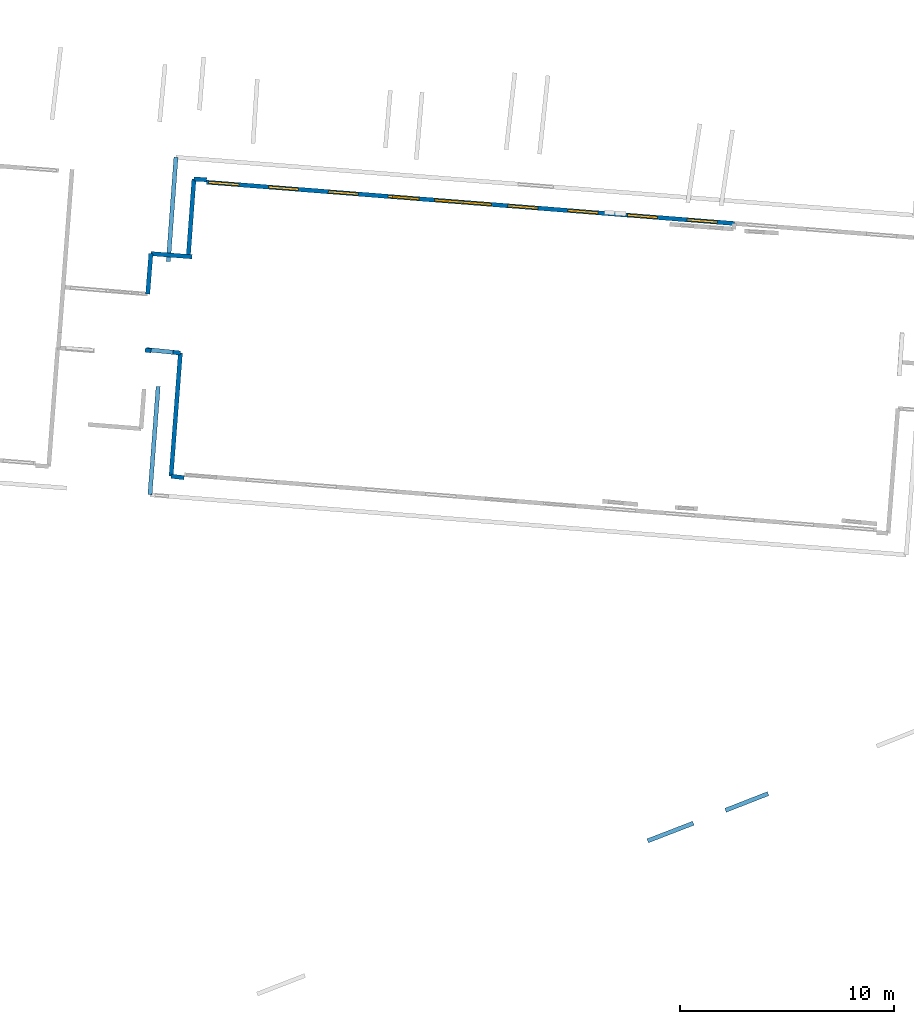
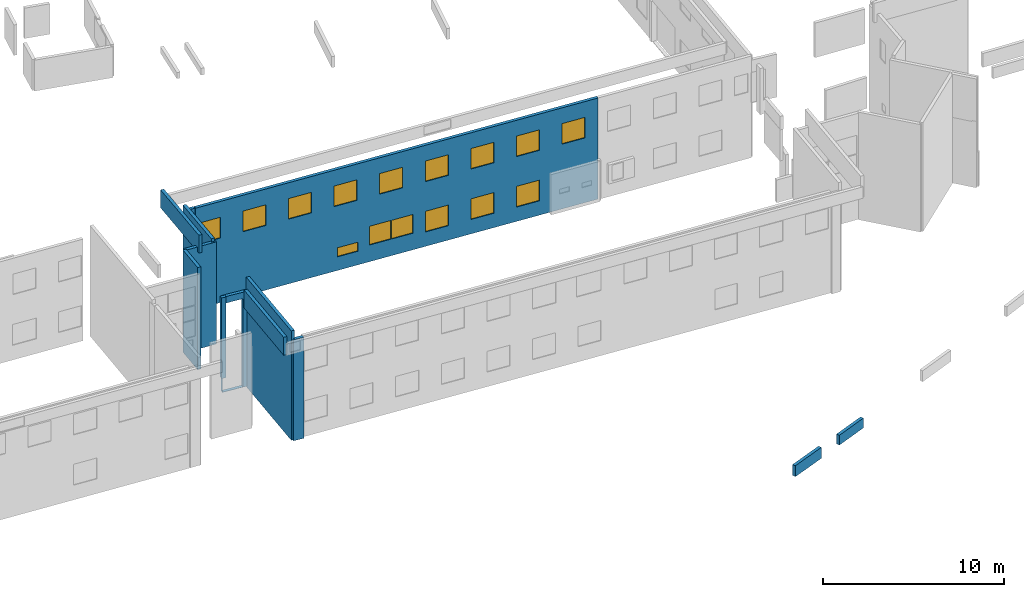
# One storey, part 16 of 27: 15 windows, 13 walls, 16 openings.
"""IFC2X3 building model written with IfcOpenShell, lengths in metres."""

from ifc_helpers import new_model, entity, si_unit, converted_unit, derived_unit, direction, frame, frame_2d, origin, origin_2d_with_axis, place, context, subcontext, project, spatial, polyline, rectangle, outline, extrude, source, transform, mapped, material, layer, layer_set, layer_usage, type_object, type_shapes, element, fill, save


model = new_model("IFC2X3")

# Units and contexts
model_context = context("Model", 3, precision=1e-05, world=origin(), true_north=direction((0.0, 1.0)))
body_context = subcontext(model_context, "Body", "Model", "MODEL_VIEW")
ifc_project = project(units=[si_unit("LENGTHUNIT", "METRE"), si_unit("AREAUNIT", "SQUARE_METRE"), si_unit("VOLUMEUNIT", "CUBIC_METRE"), converted_unit("PLANEANGLEUNIT", "DEGREE", entity("IfcRatioMeasure", 0.0174532925199433), si_unit("PLANEANGLEUNIT", "RADIAN"), dimensions=[0, 0, 0, 0, 0, 0, 0]), si_unit("MASSUNIT", "GRAM", prefix="KILO"), derived_unit("MASSDENSITYUNIT", [(si_unit("MASSUNIT", "GRAM", prefix="KILO"), 1), (si_unit("LENGTHUNIT", "METRE"), -3)]), derived_unit("MOMENTOFINERTIAUNIT", [(si_unit("LENGTHUNIT", "METRE"), 4)]), si_unit("TIMEUNIT", "SECOND"), si_unit("FREQUENCYUNIT", "HERTZ"), si_unit("THERMODYNAMICTEMPERATUREUNIT", "DEGREE_CELSIUS"), derived_unit("THERMALTRANSMITTANCEUNIT", [(si_unit("MASSUNIT", "GRAM", prefix="KILO"), 1), (si_unit("THERMODYNAMICTEMPERATUREUNIT", "KELVIN"), -1), (si_unit("TIMEUNIT", "SECOND"), -3)]), derived_unit("VOLUMETRICFLOWRATEUNIT", [(si_unit("LENGTHUNIT", "METRE"), 3), (si_unit("TIMEUNIT", "SECOND"), -1)]), si_unit("ELECTRICCURRENTUNIT", "AMPERE"), si_unit("ELECTRICVOLTAGEUNIT", "VOLT"), si_unit("POWERUNIT", "WATT"), si_unit("FORCEUNIT", "NEWTON", prefix="KILO"), si_unit("ILLUMINANCEUNIT", "LUX"), si_unit("LUMINOUSFLUXUNIT", "LUMEN"), si_unit("LUMINOUSINTENSITYUNIT", "CANDELA"), derived_unit("USERDEFINED", [(si_unit("MASSUNIT", "GRAM", prefix="KILO"), -1), (si_unit("LENGTHUNIT", "METRE"), -2), (si_unit("TIMEUNIT", "SECOND"), 3), (si_unit("LUMINOUSFLUXUNIT", "LUMEN"), 1)]), derived_unit("LINEARVELOCITYUNIT", [(si_unit("LENGTHUNIT", "METRE"), 1), (si_unit("TIMEUNIT", "SECOND"), -1)]), si_unit("PRESSUREUNIT", "PASCAL"), derived_unit("USERDEFINED", [(si_unit("LENGTHUNIT", "METRE"), -2), (si_unit("MASSUNIT", "GRAM", prefix="KILO"), 1), (si_unit("TIMEUNIT", "SECOND"), -2)]), derived_unit("LINEARFORCEUNIT", [(si_unit("MASSUNIT", "GRAM", prefix="KILO"), 1), (si_unit("LENGTHUNIT", "METRE"), 1), (si_unit("TIMEUNIT", "SECOND"), -2), (si_unit("LENGTHUNIT", "METRE"), -1)]), derived_unit("PLANARFORCEUNIT", [(si_unit("MASSUNIT", "GRAM", prefix="KILO"), 1), (si_unit("LENGTHUNIT", "METRE"), 1), (si_unit("TIMEUNIT", "SECOND"), -2), (si_unit("LENGTHUNIT", "METRE"), -2)])], contexts=[model_context])

# Site, building, storey
placement_1 = place(None, origin())
site = spatial("IfcSite", under=ifc_project, at=placement_1, CompositionType="ELEMENT")
building = spatial("IfcBuilding", under=site, at=placement_1, CompositionType="ELEMENT")
storey_placement = place(placement_1, frame((0.0, 0.0, -61.043098449707)))
storey = spatial("IfcBuildingStorey", under=building, at=storey_placement, Name="level_-61.043098", CompositionType="ELEMENT", Elevation=-61.043098449707)

# Walls
ifc_material_1 = material(Name="Default wall")
ifc_layer = layer(ifc_material_1, 0.2)
ifc_layer_set = layer_set([ifc_layer], Name="wall_thickness_0.2000")
ifc_layer_usage = layer_usage(ifc_layer_set, "AXIS2", "POSITIVE", -0.1)
wall_type = type_object("IfcWallType", Name="wall_thickness_0.2000", PredefinedType="STANDARD", material=ifc_layer_set)
wall_1_placement = place(storey_placement, frame((-30.3327727331581, -6.27983924599841, 0.0), z_axis=(0.0, 0.0, 1.0), x_axis=(-0.997044721434265, 0.0768233262757455, 0.0)))
element("IfcWallStandardCase", 1, at=wall_1_placement, inside=storey, type_object=wall_type, material=ifc_layer_usage, Name="Wall:340", ObjectType="Wall", context=body_context, shape_type="SweptSolid", body=[
    extrude(outline(polyline([(1.92745099163823, -0.1), (1.92745099163823, 0.1), (0.0, 0.1), (0.0, -0.1), (1.92745099163823, -0.1)])), origin(), (0.0, 0.0, 1.0), 6.90997695922852),
])
placement_2 = place(placement_1, frame((0.0, 0.0, -54.4207000732422)))
wall_2_placement = place(placement_2, frame((-31.4420314985094, -6.4970824423549, 0.0), z_axis=(0.0, 0.0, 1.0), x_axis=(0.0732878255302598, 0.997310831500915, 0.0)))
element("IfcWallStandardCase", 2, at=wall_2_placement, inside=storey, type_object=wall_type, material=ifc_layer_usage, Name="Wall:399", ObjectType="Wall", context=body_context, shape_type="SweptSolid", body=[
    extrude(outline(polyline([(4.87123551173419, -0.1), (4.87123551173419, 0.1), (0.0, 0.1), (0.0, -0.1), (4.87123551173419, -0.1)])), origin(), (0.0, 0.0, 1.0), 1.21003723144531),
])
wall_3_placement = place(storey_placement, frame((-30.2444584945252, -2.65084213138611, 0.0), z_axis=(0.0, 0.0, 1.0), x_axis=(-0.0734079039568483, -0.997302000216916, 0.0)))
element("IfcWallStandardCase", 3, at=wall_3_placement, inside=storey, type_object=wall_type, material=ifc_layer_usage, Name="Wall:659", ObjectType="Wall", context=body_context, shape_type="SweptSolid", body=[
    extrude(outline(polyline([(3.62507921094114, -0.1), (3.62507921094114, 0.1), (0.0, 0.1), (0.0, -0.1), (3.62507921094114, -0.1)])), origin(), (0.0, 0.0, 1.0), 7.12580871582031),
])
wall_4_placement = place(storey_placement, frame((-29.6513659251142, -2.68648694325276, 0.0), z_axis=(0.0, 0.0, 1.0), x_axis=(-0.998198842081799, 0.059992263389174, 0.0)))
element("IfcWallStandardCase", 4, at=wall_4_placement, inside=storey, type_object=wall_type, material=ifc_layer_usage, Name="Wall:709", ObjectType="Wall", context=body_context, shape_type="SweptSolid", body=[
    extrude(outline(polyline([(0.594164055363341, -0.1), (0.594164055363341, 0.1), (0.0, 0.1), (0.0, -0.1), (0.594164055363341, -0.1)])), origin(), (0.0, 0.0, 1.0), 6.76219177246094),
])
placement_3 = place(placement_1, frame((0.0, 0.0, -59.9867630004883)))
wall_5_placement = place(placement_3, frame((-32.2471248701736, -10.6648249749143, 0.0), z_axis=(0.0, 0.0, 1.0), x_axis=(-0.990595692429401, 0.136821687390254, 0.0)))
element("IfcWallStandardCase", 5, at=wall_5_placement, inside=storey, type_object=wall_type, material=ifc_layer_usage, Name="Wall:744", ObjectType="Wall", context=body_context, shape_type="SweptSolid", body=[
    extrude(outline(polyline([(0.279999842825242, -0.1), (0.279999842825242, 0.1), (0.0, 0.1), (0.0, -0.1), (0.279999842825242, -0.1)])), origin(), (0.0, 0.0, 1.0), 5.45549392700195),
])
placement_4 = place(placement_1, frame((0.0, 0.0, -60.9578857421875)))
wall_6_placement = place(placement_4, frame((-5.4558861288516, -32.0961691788936, 0.0), z_axis=(0.0, 0.0, 1.0), x_axis=(0.931288838013348, 0.364281622088938, 0.0)))
element("IfcWallStandardCase", 6, at=wall_6_placement, inside=storey, type_object=wall_type, material=ifc_layer_usage, Name="Wall:798", ObjectType="Wall", context=body_context, shape_type="SweptSolid", body=[
    extrude(outline(polyline([(2.13644295936585, -0.1), (2.13644295936585, 0.1), (0.0, 0.1), (0.0, -0.1), (2.13644295936585, -0.1)])), origin(), (0.0, 0.0, 1.0), 0.661750793457031),
])

# Wall, opening
placement_5 = place(placement_1, frame((0.0, 0.0, -60.9578857421875)))
wall_7_placement = place(placement_5, frame((-30.8788948436771, -10.7677606037389, 0.0), z_axis=(0.0, 0.0, 1.0), x_axis=(-0.994879274320708, 0.101070418655023, 0.0)))
wall_7 = element("IfcWallStandardCase", 7, at=wall_7_placement, inside=storey, type_object=wall_type, material=ifc_layer_usage, Name="Wall:1042", ObjectType="Wall", context=body_context, shape_type="SweptSolid", body=[
    extrude(outline(polyline([(1.58687465278728, -0.1), (1.58687465278728, 0.1), (0.0, 0.1), (0.0, -0.1), (1.58687465278728, -0.1)])), origin(), (0.0, 0.0, 1.0), 6.42661666870117),
])
opening_1_placement = place(wall_7_placement, frame((0.341874747974041, -0.1, 0.01629638671875)))
element("IfcOpeningElement", 8, at=opening_1_placement, cuts=wall_7, Name="Opening : 1240 x 5970 : 132", ObjectType="Opening", context=body_context, shape_type="SweptSolid", body=[
    extrude(rectangle(XDim=1.24, YDim=5.97, at=frame_2d((2.985, 0.62), x_axis=(0.0, 1.0))), frame((0.0, 0.0, 0.0), z_axis=(0.0, 1.0, 0.0), x_axis=(0.0, 0.0, 1.0)), (0.0, 0.0, 1.0), 0.2),
])

# Walls
wall_8_placement = place(storey_placement, frame((-32.2545255454813, -6.1317669821231, 0.0), z_axis=(0.0, 0.0, 1.0), x_axis=(-0.0784278699019514, -0.996919790766861, 0.0)))
element("IfcWallStandardCase", 9, at=wall_8_placement, inside=storey, type_object=wall_type, material=ifc_layer_usage, Name="Wall:1142", ObjectType="Wall", context=body_context, shape_type="SweptSolid", body=[
    extrude(outline(polyline([(1.89412183581786, -0.1), (1.89412183581786, 0.1), (0.0, 0.1), (0.0, -0.1), (1.89412183581786, -0.1)])), origin(), (0.0, 0.0, 1.0), 6.90997695922852),
])
wall_9_placement = place(storey_placement, frame((-30.7055690613934, -16.5812876091404, 0.0), z_axis=(0.0, 0.0, 1.0), x_axis=(-0.994031352901051, 0.109094772788184, 0.0)))
element("IfcWallStandardCase", 10, at=wall_9_placement, inside=storey, type_object=wall_type, material=ifc_layer_usage, Name="Wall:1145", ObjectType="Wall", context=body_context, shape_type="SweptSolid", body=[
    extrude(outline(polyline([(0.612373915866722, -0.1), (0.612373915866722, 0.1), (0.0, 0.1), (0.0, -0.1), (0.612373915866722, -0.1)])), origin(), (0.0, 0.0, 1.0), 6.83392333984375),
])
placement_6 = place(placement_1, frame((0.0, 0.0, -54.4207000732422)))
wall_10_placement = place(placement_6, frame((-32.2988607983312, -17.3784642437076, 0.0), z_axis=(0.0, 0.0, 1.0), x_axis=(0.0755069059998019, 0.997145278856766, 0.0)))
element("IfcWallStandardCase", 11, at=wall_10_placement, inside=storey, type_object=wall_type, material=ifc_layer_usage, Name="Wall:1306", ObjectType="Wall", context=body_context, shape_type="SweptSolid", body=[
    extrude(outline(polyline([(5.06280226917499, -0.1), (5.06280226917499, 0.1), (0.0, 0.1), (0.0, -0.1), (5.06280226917499, -0.1)])), origin(), (0.0, 0.0, 1.0), 1.21003723144531),
])

# Wall, openings, windows
wall_11_placement = place(storey_placement, frame((-29.6602502687136, -2.79993296057398, 0.0), z_axis=(0.0, 0.0, 1.0), x_axis=(0.996952097446105, -0.078016122678657, 0.0)))
wall_11 = element("IfcWallStandardCase", 12, at=wall_11_placement, inside=storey, type_object=wall_type, material=ifc_layer_usage, Name="Wall:1582", ObjectType="Wall", context=body_context, shape_type="SweptSolid", body=[
    extrude(outline(polyline([(24.6974745543015, -0.1), (24.6974745543015, 0.1), (0.0, 0.1), (0.0, -0.1), (24.6974745543015, -0.1)])), origin(), (0.0, 0.0, 1.0), 6.83392333984375),
])
opening_2_placement = place(wall_11_placement, frame((10.6622287166281, -0.1, 1.12677001953125)))
opening_2 = element("IfcOpeningElement", 13, at=opening_2_placement, cuts=wall_11, Name="Opening : 1330 x 1265 : 244", ObjectType="Opening", context=body_context, shape_type="SweptSolid", body=[
    extrude(rectangle(XDim=1.33, YDim=1.265, at=frame_2d((0.6325, 0.665), x_axis=(0.0, 1.0))), frame((0.0, 0.0, 0.0), z_axis=(0.0, 1.0, 0.0), x_axis=(0.0, 0.0, 1.0)), (0.0, 0.0, 1.0), 0.2),
])
opening_3_placement = place(wall_11_placement, frame((12.01713744686, -0.1, 1.12176895141602)))
opening_3 = element("IfcOpeningElement", 14, at=opening_3_placement, cuts=wall_11, Name="Opening : 1320 x 1265 : 245", ObjectType="Opening", context=body_context, shape_type="SweptSolid", body=[
    extrude(rectangle(XDim=1.32, YDim=1.265, at=frame_2d((0.6325, 0.66), x_axis=(0.0, 1.0))), frame((0.0, 0.0, 0.0), z_axis=(0.0, 1.0, 0.0), x_axis=(0.0, 0.0, 1.0)), (0.0, 0.0, 1.0), 0.2),
])
opening_4_placement = place(wall_11_placement, frame((8.49587485002833, -0.1, 4.37840270996094)))
opening_4 = element("IfcOpeningElement", 15, at=opening_4_placement, cuts=wall_11, Name="Opening : 1405 x 1390 : 246", ObjectType="Opening", context=body_context, shape_type="SweptSolid", body=[
    extrude(rectangle(XDim=1.405, YDim=1.39, at=frame_2d((0.695, 0.7025), x_axis=(0.0, 1.0))), frame((0.0, 0.0, 0.0), z_axis=(0.0, 1.0, 0.0), x_axis=(0.0, 0.0, 1.0)), (0.0, 0.0, 1.0), 0.2),
])
opening_5_placement = place(wall_11_placement, frame((11.2908736870222, -0.1, 4.37840270996094)))
opening_5 = element("IfcOpeningElement", 16, at=opening_5_placement, cuts=wall_11, Name="Opening : 1410 x 1390 : 247", ObjectType="Opening", context=body_context, shape_type="SweptSolid", body=[
    extrude(rectangle(XDim=1.41, YDim=1.39, at=frame_2d((0.695, 0.705), x_axis=(0.0, 1.0))), frame((0.0, 0.0, 0.0), z_axis=(0.0, 1.0, 0.0), x_axis=(0.0, 0.0, 1.0)), (0.0, 0.0, 1.0), 0.2),
])
opening_6_placement = place(wall_11_placement, frame((14.0908745368561, -0.1, 4.37840270996094)))
opening_6 = element("IfcOpeningElement", 17, at=opening_6_placement, cuts=wall_11, Name="Opening : 1410 x 1390 : 248", ObjectType="Opening", context=body_context, shape_type="SweptSolid", body=[
    extrude(rectangle(XDim=1.41, YDim=1.39, at=frame_2d((0.695, 0.705), x_axis=(0.0, 1.0))), frame((0.0, 0.0, 0.0), z_axis=(0.0, 1.0, 0.0), x_axis=(0.0, 0.0, 1.0)), (0.0, 0.0, 1.0), 0.2),
])
opening_7_placement = place(wall_11_placement, frame((16.900874621331, -0.1, 4.38339996337891)))
opening_7 = element("IfcOpeningElement", 18, at=opening_7_placement, cuts=wall_11, Name="Opening : 1410 x 1385 : 249", ObjectType="Opening", context=body_context, shape_type="SweptSolid", body=[
    extrude(rectangle(XDim=1.41, YDim=1.385, at=frame_2d((0.6925, 0.705), x_axis=(0.0, 1.0))), frame((0.0, 0.0, 0.0), z_axis=(0.0, 1.0, 0.0), x_axis=(0.0, 0.0, 1.0)), (0.0, 0.0, 1.0), 0.2),
])
opening_8_placement = place(wall_11_placement, frame((19.695874390492, -0.1, 4.38339996337891)))
opening_8 = element("IfcOpeningElement", 19, at=opening_8_placement, cuts=wall_11, Name="Opening : 1410 x 1385 : 250", ObjectType="Opening", context=body_context, shape_type="SweptSolid", body=[
    extrude(rectangle(XDim=1.41, YDim=1.385, at=frame_2d((0.6925, 0.705), x_axis=(0.0, 1.0))), frame((0.0, 0.0, 0.0), z_axis=(0.0, 1.0, 0.0), x_axis=(0.0, 0.0, 1.0)), (0.0, 0.0, 1.0), 0.2),
])
opening_9_placement = place(wall_11_placement, frame((22.485873153382, -0.1, 4.37840270996094)))
opening_9 = element("IfcOpeningElement", 20, at=opening_9_placement, cuts=wall_11, Name="Opening : 1410 x 1390 : 251", ObjectType="Opening", context=body_context, shape_type="SweptSolid", body=[
    extrude(rectangle(XDim=1.41, YDim=1.39, at=frame_2d((0.695, 0.705), x_axis=(0.0, 1.0))), frame((0.0, 0.0, 0.0), z_axis=(0.0, 1.0, 0.0), x_axis=(0.0, 0.0, 1.0)), (0.0, 0.0, 1.0), 0.2),
])
opening_10_placement = place(wall_11_placement, frame((0.100005771037718, -0.1, 4.35840225219727)))
opening_10 = element("IfcOpeningElement", 21, at=opening_10_placement, cuts=wall_11, Name="Opening : 1410 x 1405 : 252", ObjectType="Opening", context=body_context, shape_type="SweptSolid", body=[
    extrude(rectangle(XDim=1.41, YDim=1.405, at=frame_2d((0.7025, 0.705), x_axis=(0.0, 1.0))), frame((0.0, 0.0, 0.0), z_axis=(0.0, 1.0, 0.0), x_axis=(0.0, 0.0, 1.0)), (0.0, 0.0, 1.0), 0.2),
])
opening_11_placement = place(wall_11_placement, frame((2.89587507049625, -0.1, 4.36840057373047)))
opening_11 = element("IfcOpeningElement", 22, at=opening_11_placement, cuts=wall_11, Name="Opening : 1405 x 1395 : 253", ObjectType="Opening", context=body_context, shape_type="SweptSolid", body=[
    extrude(rectangle(XDim=1.405, YDim=1.395, at=frame_2d((0.6975, 0.7025), x_axis=(0.0, 1.0))), frame((0.0, 0.0, 0.0), z_axis=(0.0, 1.0, 0.0), x_axis=(0.0, 0.0, 1.0)), (0.0, 0.0, 1.0), 0.2),
])
opening_12_placement = place(wall_11_placement, frame((5.69587496956254, -0.1, 4.3734016418457)))
opening_12 = element("IfcOpeningElement", 23, at=opening_12_placement, cuts=wall_11, Name="Opening : 1410 x 1390 : 254", ObjectType="Opening", context=body_context, shape_type="SweptSolid", body=[
    extrude(rectangle(XDim=1.41, YDim=1.39, at=frame_2d((0.695, 0.705), x_axis=(0.0, 1.0))), frame((0.0, 0.0, 0.0), z_axis=(0.0, 1.0, 0.0), x_axis=(0.0, 0.0, 1.0)), (0.0, 0.0, 1.0), 0.2),
])
opening_13_placement = place(wall_11_placement, frame((14.0958746295604, -0.1, 0.973400115966797)))
opening_13 = element("IfcOpeningElement", 24, at=opening_13_placement, cuts=wall_11, Name="Opening : 1410 x 1395 : 255", ObjectType="Opening", context=body_context, shape_type="SweptSolid", body=[
    extrude(rectangle(XDim=1.41, YDim=1.395, at=frame_2d((0.6975, 0.705), x_axis=(0.0, 1.0))), frame((0.0, 0.0, 0.0), z_axis=(0.0, 1.0, 0.0), x_axis=(0.0, 0.0, 1.0)), (0.0, 0.0, 1.0), 0.2),
])
opening_14_placement = place(wall_11_placement, frame((16.8958735406581, -0.1, 0.973400115966797)))
opening_14 = element("IfcOpeningElement", 25, at=opening_14_placement, cuts=wall_11, Name="Opening : 1415 x 1395 : 256", ObjectType="Opening", context=body_context, shape_type="SweptSolid", body=[
    extrude(rectangle(XDim=1.415, YDim=1.395, at=frame_2d((0.6975, 0.7075), x_axis=(0.0, 1.0))), frame((0.0, 0.0, 0.0), z_axis=(0.0, 1.0, 0.0), x_axis=(0.0, 0.0, 1.0)), (0.0, 0.0, 1.0), 0.2),
])
opening_15_placement = place(wall_11_placement, frame((19.6908733470201, -0.1, 0.968399047851562)))
opening_15 = element("IfcOpeningElement", 26, at=opening_15_placement, cuts=wall_11, Name="Opening : 1415 x 1400 : 257", ObjectType="Opening", context=body_context, shape_type="SweptSolid", body=[
    extrude(rectangle(XDim=1.415, YDim=1.4, at=frame_2d((0.7, 0.7075), x_axis=(0.0, 1.0))), frame((0.0, 0.0, 0.0), z_axis=(0.0, 1.0, 0.0), x_axis=(0.0, 0.0, 1.0)), (0.0, 0.0, 1.0), 0.2),
])
opening_16_placement = place(wall_11_placement, frame((8.70461998163483, -0.1, 0.921886444091797)))
opening_16 = element("IfcOpeningElement", 27, at=opening_16_placement, cuts=wall_11, Name="Opening : 1240 x 610 : 258", ObjectType="Opening", context=body_context, shape_type="SweptSolid", body=[
    extrude(rectangle(XDim=1.24, YDim=0.61, at=frame_2d((0.305, 0.62), x_axis=(0.0, 1.0))), frame((0.0, 0.0, 0.0), z_axis=(0.0, 1.0, 0.0), x_axis=(0.0, 0.0, 1.0)), (0.0, 0.0, 1.0), 0.2),
])
ifc_material_2 = material(Name="Window Default")
window_style_1 = type_object("IfcWindowStyle", Name="Window : 1410 x 1395mm", ConstructionType="NOTDEFINED", OperationType="NOTDEFINED", ParameterTakesPrecedence=False, Sizeable=False, material=ifc_material_2)
shared_shape_1 = source(origin(), body_context, "Body", "SweptSolid", [
    extrude(rectangle(XDim=0.1, YDim=1.41, at=origin_2d_with_axis()), frame((0.705, 0.1, 0.0), z_axis=(0.0, 0.0, 1.0), x_axis=(0.0, 1.0, 0.0)), (0.0, 0.0, 1.0), 1.395),
])
type_shapes(window_style_1, [shared_shape_1])
window_1_placement = place(opening_13_placement, origin())
window_1 = element("IfcWindow", 28, at=window_1_placement, inside=storey, type_object=window_style_1, Name="Window : 1410 x 1395mm : 238", ObjectType="Window : 1410 x 1395mm", OverallHeight=1.395, OverallWidth=1.41, context=body_context, shape_type="MappedRepresentation", body=[
    mapped(shared_shape_1, transform((0.0, 0.0, 0.0), scale=1.0)),
])
fill(opening_13, window_1)
window_style_2 = type_object("IfcWindowStyle", Name="Window : 1410 x 1390mm", ConstructionType="NOTDEFINED", OperationType="NOTDEFINED", ParameterTakesPrecedence=False, Sizeable=False, material=ifc_material_2)
shared_shape_2 = source(origin(), body_context, "Body", "SweptSolid", [
    extrude(rectangle(XDim=0.1, YDim=1.41, at=origin_2d_with_axis()), frame((0.705, 0.1, 0.0), z_axis=(0.0, 0.0, 1.0), x_axis=(0.0, 1.0, 0.0)), (0.0, 0.0, 1.0), 1.39),
])
type_shapes(window_style_2, [shared_shape_2])
window_2_placement = place(opening_5_placement, origin())
window_2 = element("IfcWindow", 29, at=window_2_placement, inside=storey, type_object=window_style_2, Name="Window : 1410 x 1390mm : 230", ObjectType="Window : 1410 x 1390mm", OverallHeight=1.39, OverallWidth=1.41, context=body_context, shape_type="MappedRepresentation", body=[
    mapped(shared_shape_2, transform((0.0, 0.0, 0.0), scale=1.0)),
])
fill(opening_5, window_2)
window_3_placement = place(opening_6_placement, origin())
window_3 = element("IfcWindow", 30, at=window_3_placement, inside=storey, type_object=window_style_2, Name="Window : 1410 x 1390mm : 231", ObjectType="Window : 1410 x 1390mm", OverallHeight=1.39, OverallWidth=1.41, context=body_context, shape_type="MappedRepresentation", body=[
    mapped(shared_shape_2, transform((0.0, 0.0, 0.0), scale=1.0)),
])
fill(opening_6, window_3)
window_4_placement = place(opening_9_placement, origin())
window_4 = element("IfcWindow", 31, at=window_4_placement, inside=storey, type_object=window_style_2, Name="Window : 1410 x 1390mm : 234", ObjectType="Window : 1410 x 1390mm", OverallHeight=1.39, OverallWidth=1.41, context=body_context, shape_type="MappedRepresentation", body=[
    mapped(shared_shape_2, transform((0.0, 0.0, 0.0), scale=1.0)),
])
fill(opening_9, window_4)
window_5_placement = place(opening_12_placement, origin())
window_5 = element("IfcWindow", 32, at=window_5_placement, inside=storey, type_object=window_style_2, Name="Window : 1410 x 1390mm : 237", ObjectType="Window : 1410 x 1390mm", OverallHeight=1.39, OverallWidth=1.41, context=body_context, shape_type="MappedRepresentation", body=[
    mapped(shared_shape_2, transform((0.0, 0.0, 0.0), scale=1.0)),
])
fill(opening_12, window_5)
window_style_3 = type_object("IfcWindowStyle", Name="Window : 1415 x 1400mm", ConstructionType="NOTDEFINED", OperationType="NOTDEFINED", ParameterTakesPrecedence=False, Sizeable=False, material=ifc_material_2)
shared_shape_3 = source(origin(), body_context, "Body", "SweptSolid", [
    extrude(rectangle(XDim=0.1, YDim=1.415, at=origin_2d_with_axis()), frame((0.7075, 0.1, 0.0), z_axis=(0.0, 0.0, 1.0), x_axis=(0.0, 1.0, 0.0)), (0.0, 0.0, 1.0), 1.4),
])
type_shapes(window_style_3, [shared_shape_3])
window_6_placement = place(opening_15_placement, origin())
window_6 = element("IfcWindow", 33, at=window_6_placement, inside=storey, type_object=window_style_3, Name="Window : 1415 x 1400mm : 240", ObjectType="Window : 1415 x 1400mm", OverallHeight=1.4, OverallWidth=1.415, context=body_context, shape_type="MappedRepresentation", body=[
    mapped(shared_shape_3, transform((0.0, 0.0, 0.0), scale=1.0)),
])
fill(opening_15, window_6)
window_style_4 = type_object("IfcWindowStyle", Name="Window : 1405 x 1395mm", ConstructionType="NOTDEFINED", OperationType="NOTDEFINED", ParameterTakesPrecedence=False, Sizeable=False, material=ifc_material_2)
shared_shape_4 = source(origin(), body_context, "Body", "SweptSolid", [
    extrude(rectangle(XDim=0.1, YDim=1.405, at=origin_2d_with_axis()), frame((0.7025, 0.1, 0.0), z_axis=(0.0, 0.0, 1.0), x_axis=(0.0, 1.0, 0.0)), (0.0, 0.0, 1.0), 1.395),
])
type_shapes(window_style_4, [shared_shape_4])
window_7_placement = place(opening_11_placement, origin())
window_7 = element("IfcWindow", 34, at=window_7_placement, inside=storey, type_object=window_style_4, Name="Window : 1405 x 1395mm : 236", ObjectType="Window : 1405 x 1395mm", OverallHeight=1.395, OverallWidth=1.405, context=body_context, shape_type="MappedRepresentation", body=[
    mapped(shared_shape_4, transform((0.0, 0.0, 0.0), scale=1.0)),
])
fill(opening_11, window_7)
window_style_5 = type_object("IfcWindowStyle", Name="Window : 1415 x 1395mm", ConstructionType="NOTDEFINED", OperationType="NOTDEFINED", ParameterTakesPrecedence=False, Sizeable=False, material=ifc_material_2)
shared_shape_5 = source(origin(), body_context, "Body", "SweptSolid", [
    extrude(rectangle(XDim=0.1, YDim=1.415, at=origin_2d_with_axis()), frame((0.7075, 0.1, 0.0), z_axis=(0.0, 0.0, 1.0), x_axis=(0.0, 1.0, 0.0)), (0.0, 0.0, 1.0), 1.395),
])
type_shapes(window_style_5, [shared_shape_5])
window_8_placement = place(opening_14_placement, origin())
window_8 = element("IfcWindow", 35, at=window_8_placement, inside=storey, type_object=window_style_5, Name="Window : 1415 x 1395mm : 239", ObjectType="Window : 1415 x 1395mm", OverallHeight=1.395, OverallWidth=1.415, context=body_context, shape_type="MappedRepresentation", body=[
    mapped(shared_shape_5, transform((0.0, 0.0, 0.0), scale=1.0)),
])
fill(opening_14, window_8)
window_style_6 = type_object("IfcWindowStyle", Name="Window : 1410 x 1385mm", ConstructionType="NOTDEFINED", OperationType="NOTDEFINED", ParameterTakesPrecedence=False, Sizeable=False, material=ifc_material_2)
shared_shape_6 = source(origin(), body_context, "Body", "SweptSolid", [
    extrude(rectangle(XDim=0.1, YDim=1.41, at=origin_2d_with_axis()), frame((0.705, 0.1, 0.0), z_axis=(0.0, 0.0, 1.0), x_axis=(0.0, 1.0, 0.0)), (0.0, 0.0, 1.0), 1.385),
])
type_shapes(window_style_6, [shared_shape_6])
window_9_placement = place(opening_7_placement, origin())
window_9 = element("IfcWindow", 36, at=window_9_placement, inside=storey, type_object=window_style_6, Name="Window : 1410 x 1385mm : 232", ObjectType="Window : 1410 x 1385mm", OverallHeight=1.385, OverallWidth=1.41, context=body_context, shape_type="MappedRepresentation", body=[
    mapped(shared_shape_6, transform((0.0, 0.0, 0.0), scale=1.0)),
])
fill(opening_7, window_9)
window_10_placement = place(opening_8_placement, origin())
window_10 = element("IfcWindow", 37, at=window_10_placement, inside=storey, type_object=window_style_6, Name="Window : 1410 x 1385mm : 233", ObjectType="Window : 1410 x 1385mm", OverallHeight=1.385, OverallWidth=1.41, context=body_context, shape_type="MappedRepresentation", body=[
    mapped(shared_shape_6, transform((0.0, 0.0, 0.0), scale=1.0)),
])
fill(opening_8, window_10)
window_style_7 = type_object("IfcWindowStyle", Name="Window : 1405 x 1390mm", ConstructionType="NOTDEFINED", OperationType="NOTDEFINED", ParameterTakesPrecedence=False, Sizeable=False, material=ifc_material_2)
shared_shape_7 = source(origin(), body_context, "Body", "SweptSolid", [
    extrude(rectangle(XDim=0.1, YDim=1.405, at=origin_2d_with_axis()), frame((0.7025, 0.1, 0.0), z_axis=(0.0, 0.0, 1.0), x_axis=(0.0, 1.0, 0.0)), (0.0, 0.0, 1.0), 1.39),
])
type_shapes(window_style_7, [shared_shape_7])
window_11_placement = place(opening_4_placement, origin())
window_11 = element("IfcWindow", 38, at=window_11_placement, inside=storey, type_object=window_style_7, Name="Window : 1405 x 1390mm : 229", ObjectType="Window : 1405 x 1390mm", OverallHeight=1.39, OverallWidth=1.405, context=body_context, shape_type="MappedRepresentation", body=[
    mapped(shared_shape_7, transform((0.0, 0.0, 0.0), scale=1.0)),
])
fill(opening_4, window_11)
window_style_8 = type_object("IfcWindowStyle", Name="Window : 1330 x 1265mm", ConstructionType="NOTDEFINED", OperationType="NOTDEFINED", ParameterTakesPrecedence=False, Sizeable=False, material=ifc_material_2)
shared_shape_8 = source(origin(), body_context, "Body", "SweptSolid", [
    extrude(rectangle(XDim=0.1, YDim=1.33, at=origin_2d_with_axis()), frame((0.665, 0.1, 0.0), z_axis=(0.0, 0.0, 1.0), x_axis=(0.0, 1.0, 0.0)), (0.0, 0.0, 1.0), 1.265),
])
type_shapes(window_style_8, [shared_shape_8])
window_12_placement = place(opening_2_placement, origin())
window_12 = element("IfcWindow", 39, at=window_12_placement, inside=storey, type_object=window_style_8, Name="Window : 1330 x 1265mm : 227", ObjectType="Window : 1330 x 1265mm", OverallHeight=1.265, OverallWidth=1.33, context=body_context, shape_type="MappedRepresentation", body=[
    mapped(shared_shape_8, transform((0.0, 0.0, 0.0), scale=1.0)),
])
fill(opening_2, window_12)
window_style_9 = type_object("IfcWindowStyle", Name="Window : 1320 x 1265mm", ConstructionType="NOTDEFINED", OperationType="NOTDEFINED", ParameterTakesPrecedence=False, Sizeable=False, material=ifc_material_2)
shared_shape_9 = source(origin(), body_context, "Body", "SweptSolid", [
    extrude(rectangle(XDim=0.1, YDim=1.32, at=origin_2d_with_axis()), frame((0.66, 0.1, 0.0), z_axis=(0.0, 0.0, 1.0), x_axis=(0.0, 1.0, 0.0)), (0.0, 0.0, 1.0), 1.265),
])
type_shapes(window_style_9, [shared_shape_9])
window_13_placement = place(opening_3_placement, origin())
window_13 = element("IfcWindow", 40, at=window_13_placement, inside=storey, type_object=window_style_9, Name="Window : 1320 x 1265mm : 228", ObjectType="Window : 1320 x 1265mm", OverallHeight=1.265, OverallWidth=1.32, context=body_context, shape_type="MappedRepresentation", body=[
    mapped(shared_shape_9, transform((0.0, 0.0, 0.0), scale=1.0)),
])
fill(opening_3, window_13)
window_style_10 = type_object("IfcWindowStyle", Name="Window : 1410 x 1405mm", ConstructionType="NOTDEFINED", OperationType="NOTDEFINED", ParameterTakesPrecedence=False, Sizeable=False, material=ifc_material_2)
shared_shape_10 = source(origin(), body_context, "Body", "SweptSolid", [
    extrude(rectangle(XDim=0.1, YDim=1.41, at=origin_2d_with_axis()), frame((0.705, 0.1, 0.0), z_axis=(0.0, 0.0, 1.0), x_axis=(0.0, 1.0, 0.0)), (0.0, 0.0, 1.0), 1.405),
])
type_shapes(window_style_10, [shared_shape_10])
window_14_placement = place(opening_10_placement, origin())
window_14 = element("IfcWindow", 41, at=window_14_placement, inside=storey, type_object=window_style_10, Name="Window : 1410 x 1405mm : 235", ObjectType="Window : 1410 x 1405mm", OverallHeight=1.405, OverallWidth=1.41, context=body_context, shape_type="MappedRepresentation", body=[
    mapped(shared_shape_10, transform((0.0, 0.0, 0.0), scale=1.0)),
])
fill(opening_10, window_14)
window_style_11 = type_object("IfcWindowStyle", Name="Window : 1240 x 610mm", ConstructionType="NOTDEFINED", OperationType="NOTDEFINED", ParameterTakesPrecedence=False, Sizeable=False, material=ifc_material_2)
shared_shape_11 = source(origin(), body_context, "Body", "SweptSolid", [
    extrude(rectangle(XDim=0.1, YDim=1.24, at=origin_2d_with_axis()), frame((0.62, 0.1, 0.0), z_axis=(0.0, 0.0, 1.0), x_axis=(0.0, 1.0, 0.0)), (0.0, 0.0, 1.0), 0.61),
])
type_shapes(window_style_11, [shared_shape_11])
window_15_placement = place(opening_16_placement, origin())
window_15 = element("IfcWindow", 42, at=window_15_placement, inside=storey, type_object=window_style_11, Name="Window : 1240 x 610mm : 241", ObjectType="Window : 1240 x 610mm", OverallHeight=0.61, OverallWidth=1.24, context=body_context, shape_type="MappedRepresentation", body=[
    mapped(shared_shape_11, transform((0.0, 0.0, 0.0), scale=1.0)),
])
fill(opening_16, window_15)

# Walls
placement_7 = place(placement_1, frame((0.0, 0.0, -60.9578857421875)))
wall_12_placement = place(placement_7, frame((-9.08663827557755, -33.5203498223854, 0.0), z_axis=(0.0, 0.0, 1.0), x_axis=(0.932906995604135, 0.360117394127063, 0.0)))
element("IfcWallStandardCase", 43, at=wall_12_placement, inside=storey, type_object=wall_type, material=ifc_layer_usage, Name="Wall:1700", ObjectType="Wall", context=body_context, shape_type="SweptSolid", body=[
    extrude(outline(polyline([(2.28737309774276, -0.1), (2.28737309774276, 0.1), (0.0, 0.1), (0.0, -0.1), (2.28737309774276, -0.1)])), origin(), (0.0, 0.0, 1.0), 0.739894866943359),
])
wall_13_placement = place(storey_placement, frame((-30.8788929576184, -10.7677619301196, 0.0), z_axis=(0.0, 0.0, 1.0), x_axis=(-0.0755474671752242, -0.997142206610175, 0.0)))
element("IfcWallStandardCase", 44, at=wall_13_placement, inside=storey, type_object=wall_type, material=ifc_layer_usage, Name="Wall:1856", ObjectType="Wall", context=body_context, shape_type="SweptSolid", body=[
    extrude(outline(polyline([(5.76318840841513, -0.1), (5.76318840841513, 0.1), (0.0, 0.1), (0.0, -0.1), (5.76318840841513, -0.1)])), origin(), (0.0, 0.0, 1.0), 7.39469528198242),
])

save(model, "model.ifc")
